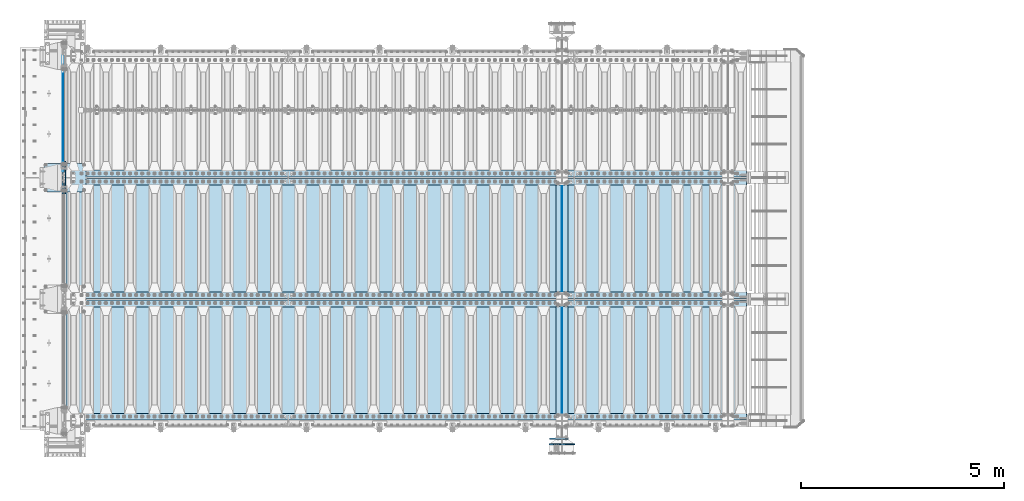
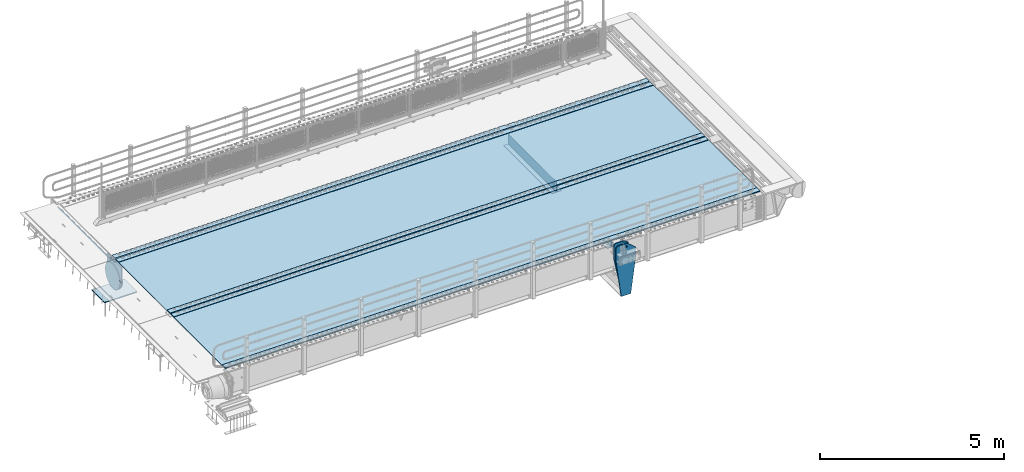
# One storey, part 193 of 247: 17 plates.
"""IFC2X3 building model written with IfcOpenShell, lengths in millimetres."""

import ifcopenshell
import ifcopenshell.guid

model = None  # the IFC model being written
_history = None  # IfcOwnerHistory: only IFC2X3 demands one
_inside = {}  # id of a spatial element -> (the spatial element, [elements in it])
_under = {}  # id of a project, library or spatial element -> (it, [spatial elements below it])
_declared = {}  # id of a project -> (the project, [libraries it declares])
_typed = {}  # id of a type object -> (the type object, [elements of that type])
_made_of = {}  # id of a material, layer set ... -> (it, [elements and type objects made of it])


def new_model(schema):
    """Start an empty IFC model of exactly this schema.

    Asked for "IFC4X3", IfcOpenShell would pick the latest addendum, in which some entities
    have other attributes; the version numbers below select the first issue.
    IFC2X3 requires an IfcOwnerHistory on every rooted entity: one is made here for all.
    """
    global model, _history
    if schema == "IFC4X3":
        model = ifcopenshell.file(schema_version=(4, 3, 0, 0))
    else:
        model = ifcopenshell.file(schema=schema)
    _inside.clear()
    _under.clear()
    _declared.clear()
    _typed.clear()
    _made_of.clear()
    _history = None
    if model.schema == "IFC2X3":
        org = make("IfcOrganization", Name="unknown")
        user = make(
            "IfcPersonAndOrganization",
            ThePerson=make("IfcPerson", FamilyName="unknown"),
            TheOrganization=org,
        )
        app = make(
            "IfcApplication",
            ApplicationDeveloper=org,
            Version="unknown",
            ApplicationFullName="unknown",
            ApplicationIdentifier="unknown",
        )
        _history = make(
            "IfcOwnerHistory",
            OwningUser=user,
            OwningApplication=app,
            ChangeAction="ADDED",
            CreationDate=0,
        )
    return model


def make(cls, **values):
    """One entity of the class cls with the attributes given. An attribute that is None is left unset."""
    return model.create_entity(
        cls, **{name: value for name, value in values.items() if value is not None}
    )


def rooted(cls, **values):
    """An entity with a GlobalId (a new one), such as an element, a storey or a relation."""
    return make(cls, GlobalId=ifcopenshell.guid.new(), OwnerHistory=_history, **values)


def si_unit(unit_type, name, prefix=None):
    """IfcSIUnit, for example si_unit("LENGTHUNIT", "METRE", prefix="MILLI")."""
    return make("IfcSIUnit", UnitType=unit_type, Prefix=prefix, Name=name)


def assignment(units):
    """IfcUnitAssignment: the units of a project."""
    return None if units is None else make("IfcUnitAssignment", Units=units)


def point(xyz):
    """IfcCartesianPoint."""
    return None if xyz is None else make("IfcCartesianPoint", Coordinates=xyz)


def direction(xyz):
    """IfcDirection."""
    return None if xyz is None else make("IfcDirection", DirectionRatios=xyz)


def frame(location, z_axis=None, x_axis=None):
    """IfcAxis2Placement3D, a coordinate frame: its origin and axes. An axis left out is left unset."""
    return make(
        "IfcAxis2Placement3D",
        Location=point(location),
        Axis=direction(z_axis),
        RefDirection=direction(x_axis),
    )


def origin_with_axes():
    """The frame at (0, 0, 0) with the z axis (0, 0, 1) and the x axis (1, 0, 0) written out."""
    return frame((0.0, 0.0, 0.0), z_axis=(0.0, 0.0, 1.0), x_axis=(1.0, 0.0, 0.0))


def place(relative_to, where):
    """IfcLocalPlacement: puts the frame where relative to a parent placement (None: the world)."""
    return make(
        "IfcLocalPlacement", PlacementRelTo=relative_to, RelativePlacement=where
    )


def context(
    kind, dimensions, precision=None, world=None, true_north=None, identifier=None
):
    """IfcGeometricRepresentationContext, for example the 3D "Model" context."""
    return make(
        "IfcGeometricRepresentationContext",
        ContextIdentifier=identifier,
        ContextType=kind,
        CoordinateSpaceDimension=dimensions,
        Precision=precision,
        WorldCoordinateSystem=world,
        TrueNorth=true_north,
    )


def subcontext(parent, identifier, kind, view, scale=None):
    """IfcGeometricRepresentationSubContext, for example "Body" below "Model"."""
    return make(
        "IfcGeometricRepresentationSubContext",
        ContextIdentifier=identifier,
        ContextType=kind,
        ParentContext=parent,
        TargetScale=scale,
        TargetView=view,
    )


def project(units=None, contexts=None):
    """IfcProject with its units and contexts."""
    return rooted(
        "IfcProject",
        Name="project",
        RepresentationContexts=contexts,
        UnitsInContext=assignment(units),
    )


def spatial(cls, under=None, at=None, **own):
    """A site, building, storey or space (cls), placed at a placement, below another one or the project."""
    s = rooted(cls, ObjectPlacement=at, **own)
    if under is not None:
        _under.setdefault(under.id(), (under, []))[1].append(s)
    return s


def faces_of(points, faces, orient=None, outer=None):
    """IfcFace entities. A face is a list of loops; a loop is a list of indices into points, from 0.

    orient and outer hold one flag for each loop. By default every Orientation is true, the
    first loop of a face is its IfcFaceOuterBound and the others are IfcFaceBound.
    """
    made = []
    for i, loops in enumerate(faces):
        bounds = []
        for j, loop in enumerate(loops):
            is_outer = j == 0 if outer is None else outer[i][j]
            bounds.append(
                make(
                    "IfcFaceOuterBound" if is_outer else "IfcFaceBound",
                    Bound=make("IfcPolyLoop", Polygon=[points[k] for k in loop]),
                    Orientation=True if orient is None else orient[i][j],
                )
            )
        made.append(make("IfcFace", Bounds=bounds))
    return made


def faceted_brep(points, faces, orient=None, outer=None, voids=None):
    """IfcFacetedBrep: a solid bounded by flat faces; with voids (closed shells), ...WithVoids."""
    shared = [point(p) for p in points]
    hull = make("IfcClosedShell", CfsFaces=faces_of(shared, faces, orient, outer))
    if voids is None:
        return make("IfcFacetedBrep", Outer=hull)
    return make(
        "IfcFacetedBrepWithVoids",
        Outer=hull,
        Voids=[
            make(cls, CfsFaces=faces_of(shared, fs, o, b)) for cls, fs, o, b in voids
        ],
    )


def shape(context_of_items, identifier, shape_type, items):
    """IfcShapeRepresentation: the items that make up one representation, for example the "Body"."""
    return make(
        "IfcShapeRepresentation",
        ContextOfItems=context_of_items,
        RepresentationIdentifier=identifier,
        RepresentationType=shape_type,
        Items=items,
    )


def material(Name=None, Category=None):
    """IfcMaterial."""
    return make("IfcMaterial", Name=Name, Category=Category)


def made_of(thing, what):
    """Note that an element or type object is made of a material, layer set ...; save() writes the relation."""
    if what is not None:
        _made_of.setdefault(what.id(), (what, []))[1].append(thing)
    return thing


def type_object(cls, material=None, **own):
    """A type object (cls), such as IfcWallType, which elements share."""
    return made_of(rooted(cls, **own), material)


def element(
    cls,
    number,
    at=None,
    inside=None,
    cuts=None,
    type_object=None,
    material=None,
    context=None,
    identifier="Body",
    shape_type=None,
    held_by="IfcProductDefinitionShape",
    body=None,
    shapes=None,
    **own,
):
    """One element of the class cls, such as IfcWall. Its Tag is "e" and its number.

    at: its placement. inside: the storey or other place that contains it. cuts: it is an
    opening in that element (IfcRelVoidsElement). A single representation is given by context,
    identifier, shape_type and body (its items); several are given by shapes. held_by: the class
    of the entity that holds the representations. save() writes the other relations.
    """
    e = rooted(cls, Tag="e%d" % number, ObjectPlacement=at, **own)
    if body is not None:
        shapes = [shape(context, identifier, shape_type, body)]
    if shapes is not None:
        e.Representation = make(held_by, Representations=shapes)
    if inside is not None:
        _inside.setdefault(inside.id(), (inside, []))[1].append(e)
    if cuts is not None:
        rooted(
            "IfcRelVoidsElement", RelatingBuildingElement=cuts, RelatedOpeningElement=e
        )
    if type_object is not None:
        _typed.setdefault(type_object.id(), (type_object, []))[1].append(e)
    return made_of(e, material)


def aggregate(whole, parts):
    """IfcRelAggregates: a whole, such as a stair, and the parts it consists of."""
    return rooted("IfcRelAggregates", RelatingObject=whole, RelatedObjects=parts)


def save(model, path):
    """Write the relations noted so far, then the file.

    IfcRelAggregates (storeys below a building ...), IfcRelContainedInSpatialStructure (elements
    in a storey), IfcRelDefinesByType, IfcRelAssociatesMaterial and IfcRelDeclares: one each for
    every whole, place, type object, material and project.
    """
    for whole, parts in _under.values():
        aggregate(whole, parts)
    for where, things in _inside.values():
        rooted(
            "IfcRelContainedInSpatialStructure",
            RelatedElements=things,
            RelatingStructure=where,
        )
    for kind, things in _typed.values():
        rooted("IfcRelDefinesByType", RelatedObjects=things, RelatingType=kind)
    for what, things in _made_of.values():
        rooted("IfcRelAssociatesMaterial", RelatedObjects=things, RelatingMaterial=what)
    for by, libraries in _declared.values():
        rooted("IfcRelDeclares", RelatingContext=by, RelatedDefinitions=libraries)
    model.write(path)


model = new_model("IFC2X3")

# Units and contexts
model_context = context("Model", 3, precision=1e-05, world=origin_with_axes())
body_context = subcontext(model_context, "Body", "Model", "MODEL_VIEW")
ifc_project = project(units=[si_unit("LENGTHUNIT", "METRE", prefix="MILLI"), si_unit("AREAUNIT", "SQUARE_METRE"), si_unit("VOLUMEUNIT", "CUBIC_METRE"), si_unit("MASSUNIT", "GRAM", prefix="KILO"), si_unit("TIMEUNIT", "SECOND"), si_unit("PLANEANGLEUNIT", "RADIAN"), si_unit("SOLIDANGLEUNIT", "STERADIAN"), si_unit("THERMODYNAMICTEMPERATUREUNIT", "DEGREE_CELSIUS"), si_unit("LUMINOUSINTENSITYUNIT", "LUMEN")], contexts=[model_context])

# Site, building, storey
site_placement = place(None, origin_with_axes())
site = spatial("IfcSite", under=ifc_project, at=site_placement, CompositionType="ELEMENT")
building_placement = place(site_placement, origin_with_axes())
building = spatial("IfcBuilding", under=site, at=building_placement, Name="Standard", CompositionType="ELEMENT")
storey_placement = place(building_placement, origin_with_axes())
storey = spatial("IfcBuildingStorey", under=building, at=storey_placement, Name="Undefined", CompositionType="ELEMENT", Elevation=0.0)

# Plates
ifc_material_1 = material(Name="STEEL/S355N")
plate_type_1 = type_object("IfcPlateType", PredefinedType="NOTDEFINED")
for number, where, z_axis, x_axis in (
    (1, (12100.0, 3175.0, -343.0), (0.0, 1.0, 0.0), (1.0, 0.0, 0.0)),
    (2, (12100.0, 175.0, -343.0), (0.0, 1.0, 0.0), (1.0, 0.0, 0.0)),
):
    element("IfcPlate", number, at=place(storey_placement, frame(where, z_axis=z_axis, x_axis=x_axis)), inside=storey, type_object=plate_type_1, material=ifc_material_1, context=body_context, shape_type="Brep", body=[
        faceted_brep([(0.0, -7.0, 0.0), (0.0, -7.0, 2650.0), (0.0, 7.0, 2650.0), (0.0, 7.0, 0.0), (300.0, -7.0, 2650.0), (300.0, 7.0, 2650.0), (300.0, -7.0, 0.0), (300.0, 7.0, 0.0)], [[[0, 1, 2, 3]], [[1, 4, 5, 2]], [[4, 6, 7, 5]], [[6, 0, 3, 7]], [[5, 7, 3, 2]], [[6, 4, 1, 0]]]),
    ])
plate_type_2 = type_object("IfcPlateType", PredefinedType="NOTDEFINED")
for number, where, z_axis, x_axis in (
    (3, (12250.0, 5825.0, 0.0), (0.0, 0.0, -1.0), (0.0, -0.999999999999548, -9.5100000000016e-07)),
    (4, (12250.0, 2825.0, 0.0), (0.0, 0.0, -1.0), (0.0, -0.999999999999548, -9.5100000000016e-07)),
):
    element("IfcPlate", number, at=place(storey_placement, frame(where, z_axis=z_axis, x_axis=x_axis)), inside=storey, type_object=plate_type_2, material=ifc_material_1, context=body_context, shape_type="Brep", body=[
        faceted_brep([(9.04219632502645e-09, -5.00000000143385, -2.89173840428703e-09), (0.0, -5.0, 336.0), (0.0, 5.0, 336.0), (7.66340235713869e-09, 4.99999999856618, -2.89173840428703e-09), (2650.0, -5.0, 336.0), (2650.0, 5.0, 336.0), (2650.0, -5.0, 0.0), (2650.0, 5.0, 0.0)], [[[0, 1, 2, 3]], [[1, 4, 5, 2]], [[4, 6, 7, 5]], [[6, 0, 3, 7]], [[5, 7, 3, 2]], [[6, 4, 1, 0]]]),
    ])
plate_type_3 = type_object("IfcPlateType", PredefinedType="NOTDEFINED")
plate_1_placement = place(storey_placement, frame((-57.5, 9002.50009937252, -35.9858217417067), z_axis=(1.00000000012752e-09, -0.999999999987744, -4.95099999993936e-06), x_axis=(0.0, 4.95099999111973e-06, -0.999999999987744)))
element("IfcPlate", 5, at=plate_1_placement, inside=storey, type_object=plate_type_3, material=ifc_material_1, context=body_context, shape_type="Brep", body=[
    faceted_brep([(0.0, -7.49999999999999, 0.0), (5.96145355302724e-12, -7.49999999999999, 150.0), (5.96145355302724e-12, 7.5, 150.0), (0.0, 7.5, 0.0), (-15.0000000000013, -7.49999999999999, 150.0), (-15.0000000000013, 7.5, 150.0), (-15.0000000000026, -7.49999999999999, 300.0), (-15.0000000000026, 7.5, 300.0), (1.00826014204358e-11, -7.49999999999999, 300.0), (1.00826014204358e-11, 7.5, 300.0), (1.05870867628255e-11, -7.49999999999999, 450.0), (1.05870867628255e-11, 7.5, 450.0), (-15.000000000004, -7.49999999999999, 450.0), (-15.000000000004, 7.5, 450.0), (-15.0000000000053, -7.49999999999999, 600.0), (-15.0000000000053, 7.5, 600.0), (1.65343294611375e-11, -7.49999999999999, 600.0), (1.65343294611375e-11, 7.5, 600.0), (1.88506987797155e-11, -7.49999999999999, 750.0), (1.88506987797155e-11, 7.5, 750.0), (-15.0000000000066, -7.49999999999999, 750.0), (-15.0000000000066, 7.5, 750.0), (-15.0000000000079, -7.49999999999999, 900.0), (-15.0000000000079, 7.5, 900.0), (2.48050469053851e-11, -7.49999999999999, 900.0), (2.48050469053851e-11, 7.5, 900.0), (2.7121416223963e-11, -7.49999999999999, 1050.0), (2.7121416223963e-11, 7.5, 1050.0), (-15.0000000000093, -7.49999999999999, 1050.0), (-15.0000000000093, 7.5, 1050.0), (-15.0000000000106, -7.49999999999999, 1200.0), (-15.0000000000106, 7.5, 1200.0), (3.12638803734444e-11, -7.49999999999999, 1200.0), (3.12638803734444e-11, 7.5, 1200.0), (3.53921336682106e-11, -7.49999999999999, 1350.0), (3.53921336682106e-11, 7.5, 1350.0), (-15.0000000000119, -7.49999999999999, 1350.0), (-15.0000000000119, 7.5, 1350.0), (-15.0000000000132, -7.49999999999999, 1500.0), (-15.0000000000132, 7.5, 1500.0), (3.77085029867885e-11, -7.49999999999999, 1500.0), (3.77085029867885e-11, 7.5, 1500.0), (4.36628511124582e-11, -7.49999999999999, 1650.0), (4.36628511124582e-11, 7.5, 1650.0), (-15.0000000000145, -7.49999999999999, 1650.0), (-15.0000000000145, 7.5, 1650.0), (-15.0000000000159, -7.49999999999999, 1800.0), (-15.0000000000159, 7.5, 1800.0), (4.41531256001326e-11, -7.49999999999999, 1800.0), (4.41531256001326e-11, 7.5, 1800.0), (4.82884843222564e-11, -7.49999999999999, 1950.0), (4.82884843222564e-11, 7.5, 1950.0), (-15.0000000000172, -7.49999999999999, 1950.0), (-15.0000000000172, 7.5, 1950.0), (-15.0000000000185, -7.49999999999999, 2100.0), (-15.0000000000185, 7.5, 2100.0), (5.24309484717378e-11, -7.49999999999999, 2100.0), (5.24309484717378e-11, 7.5, 2100.0), (5.47402123629581e-11, -7.49999999999999, 2250.0), (5.47402123629581e-11, 7.5, 2250.0), (-15.0000000000198, -7.49999999999999, 2250.0), (-15.0000000000198, 7.5, 2250.0), (-15.0000000000212, -7.49999999999999, 2400.0), (-15.0000000000212, 7.5, 2400.0), (6.06945604886278e-11, -7.49999999999999, 2400.0), (6.06945604886278e-11, 7.5, 2400.0), (6.30038243798481e-11, -7.49999999999999, 2550.0), (6.30038243798481e-11, 7.5, 2550.0), (-15.0000000000225, -7.49999999999999, 2550.0), (-15.0000000000225, 7.5, 2550.0), (-15.0000000000238, -7.49999999999999, 2700.0), (-15.0000000000238, 7.5, 2700.0), (6.53272991257836e-11, -7.49999999999999, 2700.0), (6.53272991257836e-11, 7.5, 2700.0), (7.12745418240957e-11, -7.49999999999999, 2850.0), (7.12745418240957e-11, 7.5, 2850.0), (24.9999999999749, -7.49999999999999, 2850.0), (24.9999999999749, 7.5, 2850.0), (25.0, -7.49999999999999, -1.81898940354586e-12), (25.0, 7.5, -1.81898940354586e-12)], [[[0, 1, 2, 3]], [[1, 4, 5, 2]], [[4, 6, 7, 5]], [[6, 8, 9, 7]], [[8, 10, 11, 9]], [[10, 12, 13, 11]], [[12, 14, 15, 13]], [[14, 16, 17, 15]], [[16, 18, 19, 17]], [[18, 20, 21, 19]], [[20, 22, 23, 21]], [[22, 24, 25, 23]], [[24, 26, 27, 25]], [[26, 28, 29, 27]], [[28, 30, 31, 29]], [[30, 32, 33, 31]], [[32, 34, 35, 33]], [[34, 36, 37, 35]], [[36, 38, 39, 37]], [[38, 40, 41, 39]], [[40, 42, 43, 41]], [[42, 44, 45, 43]], [[44, 46, 47, 45]], [[46, 48, 49, 47]], [[48, 50, 51, 49]], [[50, 52, 53, 51]], [[52, 54, 55, 53]], [[54, 56, 57, 55]], [[56, 58, 59, 57]], [[58, 60, 61, 59]], [[60, 62, 63, 61]], [[62, 64, 65, 63]], [[64, 66, 67, 65]], [[66, 68, 69, 67]], [[68, 70, 71, 69]], [[70, 72, 73, 71]], [[72, 74, 75, 73]], [[74, 76, 77, 75]], [[76, 78, 79, 77]], [[78, 0, 3, 79]], [[5, 7, 9, 11, 13, 15, 17, 19, 21, 23, 25, 27, 29, 31, 33, 35, 37, 39, 41, 43, 45, 47, 49, 51, 53, 55, 57, 59, 61, 63, 65, 67, 69, 71, 73, 75, 77, 79, 3, 2]], [[78, 76, 74, 72, 70, 68, 66, 64, 62, 60, 58, 56, 54, 52, 50, 48, 46, 44, 42, 40, 38, 36, 34, 32, 30, 28, 26, 24, 22, 20, 18, 16, 14, 12, 10, 8, 6, 4, 1, 0]]]),
])
plate_type_4 = type_object("IfcPlateType", PredefinedType="NOTDEFINED")
plate_2_placement = place(storey_placement, frame((-5.0, 5600.0, -20.0), z_axis=(0.0, 1.0, 0.0), x_axis=(0.0, 0.0, -1.0)))
element("IfcPlate", 6, at=plate_2_placement, inside=storey, type_object=plate_type_4, material=ifc_material_1, context=body_context, shape_type="Brep", body=[
    faceted_brep([(855.0, -15.0, 572.963114671537), (855.0, 15.0, 572.963114671537), (849.182410261294, 15.0, 585.889268817531), (849.182410261294, -15.0, 585.889268817531), (824.193546357474, 15.0, 627.225898692485), (824.193546357474, -15.0, 627.225898692485), (794.404299268454, 15.0, 665.249063296341), (794.404299268454, -15.0, 665.249063296341), (760.249063296334, 15.0, 699.404299268464), (760.249063296334, -15.0, 699.404299268464), (722.22589869248, 15.0, 729.193546357486), (722.22589869248, -15.0, 729.193546357486), (680.889268817528, 15.0, 754.182410261309), (680.889268817528, -15.0, 754.182410261309), (636.841954817037, 15.0, 774.006497074193), (636.841954817037, -15.0, 774.006497074193), (590.726265715048, 15.0, 788.37672697045), (590.726265715048, -15.0, 788.37672697045), (543.214672102156, 15.0, 797.083549639254), (543.214672102156, -15.0, 797.083549639254), (495.0, -15.0, 800.000000000029), (495.0, 15.0, 800.0), (494.999999999412, -15.0, 0.0), (494.999999999412, 15.0, 0.0), (543.214672102129, 15.0, 2.91645036080718), (543.214672102129, -15.0, 2.91645036080718), (590.726265715023, 15.0, 11.6232730296083), (590.726265715023, -15.0, 11.6232730296083), (636.841954817014, 15.0, 25.9935029258631), (636.841954817014, -15.0, 25.9935029258631), (680.889268817507, 15.0, 45.817589738745), (680.889268817507, -15.0, 45.817589738745), (722.225898692462, 15.0, 70.8064536425663), (722.225898692462, -15.0, 70.8064536425663), (760.249063296318, 15.0, 100.595700731589), (760.249063296318, -15.0, 100.595700731589), (794.404299268441, 15.0, 134.750936703711), (794.404299268441, -15.0, 134.750936703711), (824.193546357463, 15.0, 172.774101307567), (824.193546357463, -15.0, 172.774101307567), (849.182410261284, 15.0, 214.110731182522), (849.182410261284, -15.0, 214.110731182522), (855.0, -15.0, 227.036885328536), (855.0, 15.0, 227.036885328536), (0.0, -15.0, 0.0), (0.0, 15.0, 0.0), (0.0, 15.0, 800.0), (0.0, -15.0, 800.0)], [[[0, 1, 2, 3]], [[3, 2, 4, 5]], [[5, 4, 6, 7]], [[7, 6, 8, 9]], [[9, 8, 10, 11]], [[11, 10, 12, 13]], [[13, 12, 14, 15]], [[15, 14, 16, 17]], [[17, 16, 18, 19]], [[20, 19, 18, 21]], [[22, 23, 24, 25]], [[25, 24, 26, 27]], [[27, 26, 28, 29]], [[29, 28, 30, 31]], [[31, 30, 32, 33]], [[33, 32, 34, 35]], [[35, 34, 36, 37]], [[37, 36, 38, 39]], [[39, 38, 40, 41]], [[42, 41, 40, 43]], [[42, 43, 1, 0]], [[44, 45, 23, 22]], [[16, 14, 12, 10, 8, 6, 4, 2, 1, 43, 40, 38, 36, 34, 32, 30, 28, 26, 24, 23, 45, 46, 21, 18]], [[44, 47, 46, 45]], [[46, 47, 20, 21]], [[47, 44, 22, 25, 27, 29, 31, 33, 35, 37, 39, 41, 42, 0, 3, 5, 7, 9, 11, 13, 15, 17, 19, 20]]]),
])
plate_type_5 = type_object("IfcPlateType", PredefinedType="NOTDEFINED")
plate_3_placement = place(storey_placement, frame((-523.999999999996, 6350.0, -1043.0), z_axis=(1.0, 0.0, 0.0), x_axis=(0.0, -0.999999999999548, -9.5100000000016e-07)))
element("IfcPlate", 7, at=plate_3_placement, inside=storey, type_object=plate_type_5, material=ifc_material_1, context=body_context, shape_type="Brep", body=[
    faceted_brep([(0.0, -15.0, 0.0), (2.93249286187347e-06, -15.0, 1025.0), (2.93249286187347e-06, 15.0, 1025.0), (0.0, 15.0, 0.0), (700.0, -15.0, 1025.0), (700.0, 15.0, 1025.0), (700.0, -15.0, -6.3664629124105e-12), (700.0, 15.0, -6.3664629124105e-12)], [[[0, 1, 2, 3]], [[1, 4, 5, 2]], [[4, 6, 7, 5]], [[6, 0, 3, 7]], [[5, 7, 3, 2]], [[6, 4, 1, 0]]]),
])
plate_type_6 = type_object("IfcPlateType", PredefinedType="NOTDEFINED")
plate_4_placement = place(storey_placement, frame((12410.0000000273, -440.000000015418, -945.000018229049), z_axis=(-0.901283188008788, 0.0, 0.433230441004225), x_axis=(-0.433230441004223, 0.0, -0.901283188008789)))
element("IfcPlate", 8, at=plate_4_placement, inside=storey, type_object=plate_type_6, material=ifc_material_1, context=body_context, shape_type="Brep", body=[
    faceted_brep([(22.0942403519075, -14.9999999999964, 175.225838713073), (22.0942403519075, 15.0000000000036, 175.225838713073), (270.848403398947, 15.0, 55.6542354785815), (270.848403398947, -15.0, 55.6542354785815), (15.5957837368442, -14.9999999999964, 161.706590892942), (15.5957837368442, 15.0000000000036, 161.706590892942), (264.349945986183, -15.0, 42.1349880418893), (264.349945986183, 15.0, 42.1349880418893), (244.096420288085, -15.0, -6.73026079311967e-11), (244.096420288085, 15.0, -6.73026079311967e-11), (0.0, -15.0, 0.0), (0.0, 15.0, 0.0), (-976.801818847657, -14.9999999999999, 469.530853271483), (-976.801818847658, 15.0000000000001, 469.530853271481), (-1005.61098604242, -15.0, 584.572481266789), (-1005.61098604242, 15.0, 584.572481266787), (-1008.62084772112, -15.0, 603.379189822303), (-1008.62084772112, 15.0, 603.379189822303), (-1008.34151554697, -14.9999999999999, 622.423179098552), (-1008.34151554697, 15.0000000000001, 622.42317909855), (-1004.7813898293, -15.0, 641.133500175492), (-1004.7813898293, 15.0, 641.133500175492), (-998.047132923921, -15.0, 658.949304871174), (-998.047132923921, 15.0, 658.949304871174), (-903.393050005923, -14.9999999999999, 855.865691431818), (-903.393050005924, 15.0000000000001, 855.865691431818), (-891.965949445597, -15.0, 873.346281101725), (-891.965949445597, 15.0, 873.346281101723), (-876.403907448142, -15.0, 887.273681838964), (-876.403907448142, 15.0, 887.273681838962), (-857.767451990592, -14.9999999999999, 896.698763822948), (-857.767451990592, 15.0000000000001, 896.698763822949), (-837.326627351688, -15.0, 900.979222969752), (-837.326627351689, 15.0, 900.97922296975), (-816.474442649738, -15.0, 899.823352915886), (-816.474442649738, 15.0, 899.823352915884), (-796.631940525474, -15.0, 893.309924335017), (-796.631940525474, 15.0, 893.309924335017), (-427.105804443361, -15.0, 715.685363769529), (-427.105804443362, 15.0, 715.685363769529), (138.633743286132, -15.0, 288.41061401367), (138.633743286132, 15.0, 288.41061401367), (291.101928710937, -15.0, 97.7892227172833), (291.101928710937, 15.0, 97.7892227172833), (-886.324025694375, -14.9999999999964, 572.182288694507), (-886.324025694375, 15.0000000000036, 572.182288694507), (-901.776420284152, 15.0000000000036, 569.98934605829), (-901.776420284152, -14.9999999999964, 569.98934605829), (-872.8870774196, -14.9999999999964, 580.121678911952), (-872.8870774196, 15.0000000000036, 580.121678911952), (-863.511229028422, -14.9999999999964, 592.598816520775), (-863.511229028422, 15.0000000000036, 592.598816520775), (-859.623868446118, -14.9999999999964, 607.714170425565), (-859.623868446118, 15.0000000000036, 607.714170425565), (-861.816811082334, -14.9999999999964, 623.166565015341), (-861.816811082334, 15.0000000000036, 623.166565015341), (-869.756201299781, -14.9999999999964, 636.603513290116), (-869.756201299781, 15.0000000000036, 636.603513290116), (-882.233338908604, -14.9999999999964, 645.979361681295), (-882.233338908604, 15.0000000000036, 645.979361681295), (-897.348692813394, -14.9999999999964, 649.866722263598), (-897.348692813394, 15.0000000000036, 649.866722263598), (-912.801087403171, -14.9999999999964, 647.673779627383), (-912.801087403171, 15.0000000000036, 647.673779627383), (-926.238035677946, -14.9999999999964, 639.734389409936), (-926.238035677946, 15.0000000000036, 639.734389409936), (-935.613884069125, -14.9999999999964, 627.257251801113), (-935.613884069125, 15.0000000000036, 627.257251801113), (-939.501244651428, -14.9999999999964, 612.141897896323), (-939.501244651428, 15.0000000000036, 612.141897896323), (-937.308302015212, -14.9999999999964, 596.689503306548), (-937.308302015212, 15.0000000000036, 596.689503306548), (-929.368911797765, -14.9999999999964, 583.252555031771), (-929.368911797765, 15.0000000000036, 583.252555031771), (-916.891774188942, -14.9999999999964, 573.876706640593), (-916.891774188942, 15.0000000000036, 573.876706640593), (-844.133640467231, 15.0, 583.284362056664), (-843.858297550992, 15.0, 588.25162118703), (-847.175983322761, 15.0, 591.958700645248), (-852.143242453128, 15.0, 592.234043561486), (-855.850321911345, 15.0, 588.916357789718), (-856.125664827585, 15.0, 583.94909865935), (-852.807979055816, 15.0, 580.242019201134), (-847.840719925449, 15.0, 579.966676284894), (-847.840719925449, -15.0, 579.966676284894), (-852.807979055816, -15.0, 580.242019201134), (-844.133640467231, -15.0, 583.284362056664), (-843.858297550992, -15.0, 588.25162118703), (-847.175983322761, -15.0, 591.958700645248), (-852.143242453128, -15.0, 592.234043561486), (-855.850321911345, -15.0, 588.916357789718), (-856.125664827585, -15.0, 583.94909865935)], [[[0, 1, 2, 3]], [[4, 5, 1, 0]], [[6, 7, 5, 4]], [[8, 9, 7, 6]], [[8, 10, 11, 9]], [[10, 12, 13, 11]], [[12, 14, 15, 13]], [[14, 16, 17, 15]], [[16, 18, 19, 17]], [[18, 20, 21, 19]], [[20, 22, 23, 21]], [[22, 24, 25, 23]], [[24, 26, 27, 25]], [[26, 28, 29, 27]], [[28, 30, 31, 29]], [[30, 32, 33, 31]], [[32, 34, 35, 33]], [[34, 36, 37, 35]], [[36, 38, 39, 37]], [[38, 40, 41, 39]], [[40, 42, 43, 41]], [[43, 42, 3, 2]], [[44, 45, 46, 47]], [[48, 49, 45, 44]], [[50, 51, 49, 48]], [[52, 53, 51, 50]], [[54, 55, 53, 52]], [[56, 57, 55, 54]], [[58, 59, 57, 56]], [[60, 61, 59, 58]], [[62, 63, 61, 60]], [[64, 65, 63, 62]], [[66, 67, 65, 64]], [[68, 69, 67, 66]], [[70, 71, 69, 68]], [[72, 73, 71, 70]], [[74, 75, 73, 72]], [[47, 46, 75, 74]], [[9, 11, 13, 15, 17, 19, 21, 23, 25, 27, 29, 31, 33, 35, 37, 39, 41, 43, 2, 1, 5, 7], [76, 77, 78, 79, 80, 81, 82, 83], [45, 49, 51, 53, 55, 57, 59, 61, 63, 65, 67, 69, 71, 73, 75, 46]], [[84, 83, 82, 85]], [[86, 76, 83, 84]], [[87, 77, 76, 86]], [[88, 78, 77, 87]], [[89, 79, 78, 88]], [[90, 80, 79, 89]], [[91, 81, 80, 90]], [[85, 82, 81, 91]], [[3, 42, 40, 38, 36, 34, 32, 30, 28, 26, 24, 22, 20, 18, 16, 14, 12, 10, 8, 6, 4, 0], [90, 89, 88, 87, 86, 84, 85, 91], [70, 68, 66, 64, 62, 60, 58, 56, 54, 52, 50, 48, 44, 47, 74, 72]]]),
])
plate_type_7 = type_object("IfcPlateType", PredefinedType="NOTDEFINED")
plate_5_placement = place(storey_placement, frame((12400.0000000138, -580.000000015418, -1470.00001822257), z_axis=(0.0, 0.0, 1.0), x_axis=(-1.0, 0.0, 0.0)))
element("IfcPlate", 9, at=plate_5_placement, inside=storey, type_object=plate_type_7, material=ifc_material_1, context=body_context, shape_type="Brep", body=[
    faceted_brep([(145.403805922693, -14.9999999999999, 1549.59619407771), (145.403805922693, 15.0, 1549.59619407771), (150.000000000406, 15.0, 1551.5), (150.000000000406, -14.9999999999999, 1551.5), (154.596194078118, 15.0, 1549.59619407771), (154.596194078118, -14.9999999999999, 1549.59619407771), (156.500000000406, 15.0, 1545.0), (156.500000000406, -14.9999999999999, 1545.0), (154.596194078118, 15.0, 1540.40380592229), (154.596194078118, -14.9999999999999, 1540.40380592229), (150.000000000406, 15.0, 1538.5), (150.000000000406, -14.9999999999999, 1538.5), (145.403805922693, 15.0, 1540.40380592229), (145.403805922693, -14.9999999999999, 1540.40380592229), (143.500000000406, 15.0, 1545.0), (143.500000000406, -14.9999999999999, 1545.0), (300.0, -15.0, 0.0), (0.0, -15.0, 0.0), (0.0, 15.0, 0.0), (300.0, 15.0, 0.0), (462.5, -15.0, 1210.0), (462.5, 15.0, 1210.0), (462.5, -15.0, 1630.0), (462.5, 15.0, 1630.0), (459.774066103126, -15.0, 1650.7055236082), (459.774066103126, 15.0, 1650.7055236082), (451.782032302755, -15.0, 1670.0), (451.782032302755, 15.0, 1670.0), (439.068542494924, -15.0, 1686.56854249492), (439.068542494924, 15.0, 1686.56854249492), (422.5, -15.0, 1699.28203230276), (422.5, 15.0, 1699.28203230276), (403.205523608201, -15.0, 1707.27406610313), (403.205523608201, 15.0, 1707.27406610313), (382.5, -15.0, 1710.0), (382.5, 15.0, 1710.0), (151.788081037079, -15.0, 1710.0), (151.788081037079, 15.0, 1710.0), (132.694887325031, -15.0, 1708.33028179541), (132.694887325031, 15.0, 1708.33028179541), (114.181334578885, -15.0, 1703.37181734316), (114.181334578885, 15.0, 1703.37181734316), (96.8094667268542, -15.0, 1695.27513824985), (96.8094667268542, 15.0, 1695.27513824985), (81.1066678416755, -15.0, 1684.28604765144), (81.1066678416755, 15.0, 1684.28604765144), (-162.5, -15.0, 1480.0), (-162.5, 15.0, 1480.0), (-162.5, -15.0, 1210.0), (-162.5, 15.0, 1210.0), (121.715728752944, -15.0, 1628.28427124746), (134.692662705802, -15.0, 1636.95518130045), (150.000000000406, -15.0, 1640.0), (165.307337295009, -15.0, 1636.95518130045), (178.284271247867, -15.0, 1628.28427124746), (186.955181300857, -15.0, 1615.3073372946), (190.000000000406, -15.0, 1600.0), (186.955181300857, -15.0, 1584.6926627054), (178.284271247867, -15.0, 1571.71572875254), (165.307337295009, -15.0, 1563.04481869955), (150.000000000406, -15.0, 1560.0), (134.692662705802, -15.0, 1563.04481869955), (121.715728752944, -15.0, 1571.71572875254), (113.044818699955, -15.0, 1584.6926627054), (110.000000000406, -15.0, 1600.0), (113.044818699955, -15.0, 1615.3073372946), (121.715728752944, 14.999999999953, 1571.71572875254), (113.044818699955, 14.999999999953, 1584.6926627054), (134.692662705802, 14.999999999953, 1563.04481869955), (150.000000000406, 14.999999999953, 1560.0), (165.307337295009, 14.999999999953, 1563.04481869955), (178.284271247867, 14.999999999953, 1571.71572875254), (186.955181300857, 14.999999999953, 1584.6926627054), (190.000000000406, 14.999999999953, 1600.0), (186.955181300857, 14.999999999953, 1615.3073372946), (178.284271247867, 14.999999999953, 1628.28427124746), (165.307337295009, 14.999999999953, 1636.95518130045), (150.000000000406, 14.999999999953, 1640.0), (134.692662705802, 14.999999999953, 1636.95518130045), (121.715728752944, 14.999999999953, 1628.28427124746), (113.044818699955, 14.999999999953, 1615.3073372946), (110.000000000406, 14.999999999953, 1600.0)], [[[0, 1, 2, 3]], [[3, 2, 4, 5]], [[5, 4, 6, 7]], [[7, 6, 8, 9]], [[9, 8, 10, 11]], [[11, 10, 12, 13]], [[13, 12, 14, 15]], [[15, 14, 1, 0]], [[16, 17, 18, 19]], [[20, 16, 19, 21]], [[22, 20, 21, 23]], [[24, 22, 23, 25]], [[26, 24, 25, 27]], [[28, 26, 27, 29]], [[30, 28, 29, 31]], [[32, 30, 31, 33]], [[34, 32, 33, 35]], [[36, 34, 35, 37]], [[38, 36, 37, 39]], [[40, 38, 39, 41]], [[42, 40, 41, 43]], [[44, 42, 43, 45]], [[46, 44, 45, 47]], [[48, 46, 47, 49]], [[17, 48, 49, 18]], [[16, 20, 22, 24, 26, 28, 30, 32, 34, 36, 38, 40, 42, 44, 46, 48, 17], [3, 5, 7, 9, 11, 13, 15, 0], [50, 51, 52, 53, 54, 55, 56, 57, 58, 59, 60, 61, 62, 63, 64, 65]], [[62, 66, 67, 63]], [[61, 68, 66, 62]], [[60, 69, 68, 61]], [[59, 70, 69, 60]], [[58, 71, 70, 59]], [[57, 72, 71, 58]], [[56, 73, 72, 57]], [[55, 74, 73, 56]], [[54, 75, 74, 55]], [[53, 76, 75, 54]], [[52, 77, 76, 53]], [[51, 78, 77, 52]], [[50, 79, 78, 51]], [[65, 80, 79, 50]], [[64, 81, 80, 65]], [[63, 67, 81, 64]], [[47, 45, 43, 41, 39, 37, 35, 33, 31, 29, 27, 25, 23, 21, 19, 18, 49], [10, 8, 6, 4, 2, 1, 14, 12], [66, 68, 69, 70, 71, 72, 73, 74, 75, 76, 77, 78, 79, 80, 81, 67]]]),
])
ifc_material_2 = material(Name="STEEL/S235JR")
plate_type_8 = type_object("IfcPlateType", PredefinedType="NOTDEFINED")
for number, where, z_axis, x_axis in (
    (10, (16807.0, 6015.0, 20.0), (-1.0, 0.0, 0.0), (0.0, 1.0, 0.0)),
    (11, (16807.0, 5815.0, 20.0), (-1.0, 0.0, 0.0), (0.0, 1.0, 0.0)),
    (12, (16807.0, 3015.0, 20.0), (-1.0, 0.0, 0.0), (0.0, 1.0, 0.0)),
    (13, (16807.0, 2815.0, 20.0), (-1.0, 0.0, 0.0), (0.0, 1.0, 0.0)),
    (14, (16807.0, 15.0, 20.0), (-1.0, 0.0, 0.0), (0.0, 1.0, 0.0)),
):
    element("IfcPlate", number, at=place(storey_placement, frame(where, z_axis=z_axis, x_axis=x_axis)), inside=storey, type_object=plate_type_8, material=ifc_material_2, context=body_context, shape_type="Brep", body=[
        faceted_brep([(0.0, -6.0, 0.0), (0.0, -6.0, 16787.0), (0.0, 6.0, 16787.0), (0.0, 6.0, 0.0), (170.0, -6.0, 16787.0), (170.0, 6.0, 16787.0), (170.0, -6.0, 0.0), (170.0, 6.0, 0.0)], [[[0, 1, 2, 3]], [[1, 4, 5, 2]], [[4, 6, 7, 5]], [[6, 0, 3, 7]], [[5, 7, 3, 2]], [[6, 4, 1, 0]]]),
    ])
plate_type_9 = type_object("IfcPlateType", PredefinedType="NOTDEFINED")
for number, where, z_axis, x_axis in (
    (15, (10.0, 5995.0, 7.0), (1.0, 0.0, 0.0), (0.0, -0.999999999999548, -9.5100000000016e-07)),
    (16, (10.0, 2995.0, 7.0), (1.0, 0.0, 0.0), (0.0, -0.999999999999548, -9.5100000000016e-07)),
):
    element("IfcPlate", number, at=place(storey_placement, frame(where, z_axis=z_axis, x_axis=x_axis)), inside=storey, type_object=plate_type_9, material=ifc_material_1, context=body_context, shape_type="Brep", body=[
        faceted_brep([(0.0, -7.0, 0.0), (-2.96859070658684e-09, -7.0, 16807.0), (-2.96859070658684e-09, 7.0, 16807.0), (0.0, 7.0, 0.0), (2990.0, -7.0, 16807.0), (2990.0, 7.0, 16807.0), (2990.0, -7.0, 0.0), (2990.0, 7.0, 0.0)], [[[0, 1, 2, 3]], [[1, 4, 5, 2]], [[4, 6, 7, 5]], [[6, 0, 3, 7]], [[5, 7, 3, 2]], [[6, 4, 1, 0]]]),
    ])
plate_type_10 = type_object("IfcPlateType", PredefinedType="NOTDEFINED")
plate_6_placement = place(storey_placement, frame((-62.5000000000001, 6400.0, -114.999999999998), z_axis=(0.0, 0.0, -1.0), x_axis=(0.0, -0.999999999999548, -9.5100000000016e-07)))
element("IfcPlate", 17, at=plate_6_placement, inside=storey, type_object=plate_type_10, material=ifc_material_1, context=body_context, shape_type="Brep", body=[
    faceted_brep([(0.0, -12.5, 400.0), (2.91645036077898, -12.5, 448.214672102129), (2.91645036077898, 12.5, 448.214672102129), (0.0, 12.5, 400.0), (11.6232730295797, -12.5, 495.726265715023), (11.6232730295797, 12.5, 495.726265715023), (25.993502925834, -12.5, 541.841954817014), (25.993502925834, 12.5, 541.841954817014), (45.8175897387155, -12.5, 585.889268817507), (45.8175897387155, 12.5, 585.889268817507), (70.8064536425372, -12.5, 627.225898692462), (70.8064536425372, 12.5, 627.225898692462), (100.595700731559, -12.5, 665.249063296318), (100.595700731559, 12.5, 665.249063296318), (134.750936703682, -12.5, 699.40429926844), (134.750936703682, 12.5, 699.40429926844), (172.774101307537, -12.5, 729.193546357462), (172.774101307537, 12.5, 729.193546357462), (214.110731182493, -12.5, 754.182410261284), (214.110731182493, 12.5, 754.182410261284), (258.158045182985, -12.5, 774.006497074166), (258.158045182985, 12.5, 774.006497074166), (304.273734284976, -12.5, 788.376726970421), (304.273734284976, 12.5, 788.376726970421), (351.785327897871, -12.5, 797.083549639221), (351.785327897871, 12.5, 797.083549639221), (400.0, -12.5, 800.0), (400.0, 12.5, 800.0), (448.214672102129, -12.5, 797.083549639222), (448.214672102129, 12.5, 797.083549639222), (495.726265715022, -12.5, 788.376726970421), (495.726265715022, 12.5, 788.376726970421), (541.841954817013, -12.5, 774.006497074166), (541.841954817013, 12.5, 774.006497074166), (585.889268817507, -12.5, 754.182410261284), (585.889268817507, 12.5, 754.182410261284), (627.225898692463, -12.5, 729.193546357463), (627.225898692463, 12.5, 729.193546357463), (665.249063296318, -12.5, 699.404299268441), (665.249063296318, 12.5, 699.404299268441), (699.404299268441, -12.5, 665.249063296318), (699.404299268441, 12.5, 665.249063296318), (729.193546357463, -12.5, 627.225898692462), (729.193546357463, 12.5, 627.225898692462), (754.182410261285, -12.5, 585.889268817507), (754.182410261285, 12.5, 585.889268817507), (774.006497074166, -12.5, 541.841954817014), (774.006497074166, 12.5, 541.841954817014), (788.37672697042, -12.5, 495.726265715023), (788.37672697042, 12.5, 495.726265715023), (797.083549639221, -12.5, 448.214672102129), (797.083549639221, 12.5, 448.214672102129), (800.0, -12.5, 400.0), (800.0, 12.5, 400.0), (797.083549639221, -12.5, 351.785327897871), (797.083549639221, 12.5, 351.785327897871), (788.37672697042, -12.5, 304.273734284977), (788.37672697042, 12.5, 304.273734284977), (774.006497074166, -12.5, 258.158045182986), (774.006497074166, 12.5, 258.158045182986), (754.182410261285, -12.5, 214.110731182493), (754.182410261285, 12.5, 214.110731182493), (729.193546357463, -12.5, 172.774101307538), (729.193546357463, 12.5, 172.774101307538), (699.404299268441, -12.5, 134.750936703682), (699.404299268441, 12.5, 134.750936703682), (665.249063296318, -12.5, 100.59570073156), (665.249063296318, 12.5, 100.59570073156), (627.225898692463, -12.5, 70.8064536425375), (627.225898692463, 12.5, 70.8064536425375), (585.889268817507, -12.5, 45.817589738716), (585.889268817507, 12.5, 45.817589738716), (541.841954817015, -12.5, 25.9935029258342), (541.841954817015, 12.5, 25.9935029258342), (495.726265715024, -12.5, 11.6232730295793), (495.726265715024, 12.5, 11.6232730295793), (448.214672102129, -12.5, 2.91645036077847), (448.214672102129, 12.5, 2.91645036077847), (400.0, -12.5, -5.6843418860808e-14), (400.0, 12.5, -5.6843418860808e-14), (351.785327897871, -12.5, 2.91645036077836), (351.785327897871, 12.5, 2.91645036077836), (304.273734284976, -12.5, 11.6232730295792), (304.273734284976, 12.5, 11.6232730295792), (258.158045182985, -12.5, 25.993502925834), (258.158045182985, 12.5, 25.993502925834), (214.110731182493, -12.5, 45.817589738716), (214.110731182493, 12.5, 45.817589738716), (172.774101307537, -12.5, 70.8064536425374), (172.774101307537, 12.5, 70.8064536425374), (134.750936703682, -12.5, 100.595700731559), (134.750936703682, 12.5, 100.595700731559), (100.595700731559, -12.5, 134.750936703682), (100.595700731559, 12.5, 134.750936703682), (70.8064536425372, -12.5, 172.774101307538), (70.8064536425372, 12.5, 172.774101307538), (45.8175897387155, -12.5, 214.110731182492), (45.8175897387155, 12.5, 214.110731182492), (25.993502925834, -12.5, 258.158045182986), (25.993502925834, 12.5, 258.158045182986), (11.6232730295797, -12.5, 304.273734284977), (11.6232730295797, 12.5, 304.273734284977), (2.91645036077898, -12.5, 351.785327897871), (2.91645036077898, 12.5, 351.785327897871)], [[[0, 1, 2, 3]], [[1, 4, 5, 2]], [[4, 6, 7, 5]], [[6, 8, 9, 7]], [[8, 10, 11, 9]], [[10, 12, 13, 11]], [[12, 14, 15, 13]], [[14, 16, 17, 15]], [[16, 18, 19, 17]], [[18, 20, 21, 19]], [[20, 22, 23, 21]], [[22, 24, 25, 23]], [[24, 26, 27, 25]], [[26, 28, 29, 27]], [[28, 30, 31, 29]], [[30, 32, 33, 31]], [[32, 34, 35, 33]], [[34, 36, 37, 35]], [[36, 38, 39, 37]], [[38, 40, 41, 39]], [[40, 42, 43, 41]], [[42, 44, 45, 43]], [[44, 46, 47, 45]], [[46, 48, 49, 47]], [[48, 50, 51, 49]], [[50, 52, 53, 51]], [[52, 54, 55, 53]], [[54, 56, 57, 55]], [[56, 58, 59, 57]], [[58, 60, 61, 59]], [[60, 62, 63, 61]], [[62, 64, 65, 63]], [[64, 66, 67, 65]], [[66, 68, 69, 67]], [[68, 70, 71, 69]], [[70, 72, 73, 71]], [[72, 74, 75, 73]], [[74, 76, 77, 75]], [[76, 78, 79, 77]], [[78, 80, 81, 79]], [[80, 82, 83, 81]], [[82, 84, 85, 83]], [[84, 86, 87, 85]], [[86, 88, 89, 87]], [[88, 90, 91, 89]], [[90, 92, 93, 91]], [[92, 94, 95, 93]], [[94, 96, 97, 95]], [[96, 98, 99, 97]], [[98, 100, 101, 99]], [[100, 102, 103, 101]], [[102, 0, 3, 103]], [[5, 7, 9, 11, 13, 15, 17, 19, 21, 23, 25, 27, 29, 31, 33, 35, 37, 39, 41, 43, 45, 47, 49, 51, 53, 55, 57, 59, 61, 63, 65, 67, 69, 71, 73, 75, 77, 79, 81, 83, 85, 87, 89, 91, 93, 95, 97, 99, 101, 103, 3, 2]], [[102, 100, 98, 96, 94, 92, 90, 88, 86, 84, 82, 80, 78, 76, 74, 72, 70, 68, 66, 64, 62, 60, 58, 56, 54, 52, 50, 48, 46, 44, 42, 40, 38, 36, 34, 32, 30, 28, 26, 24, 22, 20, 18, 16, 14, 12, 10, 8, 6, 4, 1, 0]]]),
])

save(model, "model.ifc")
